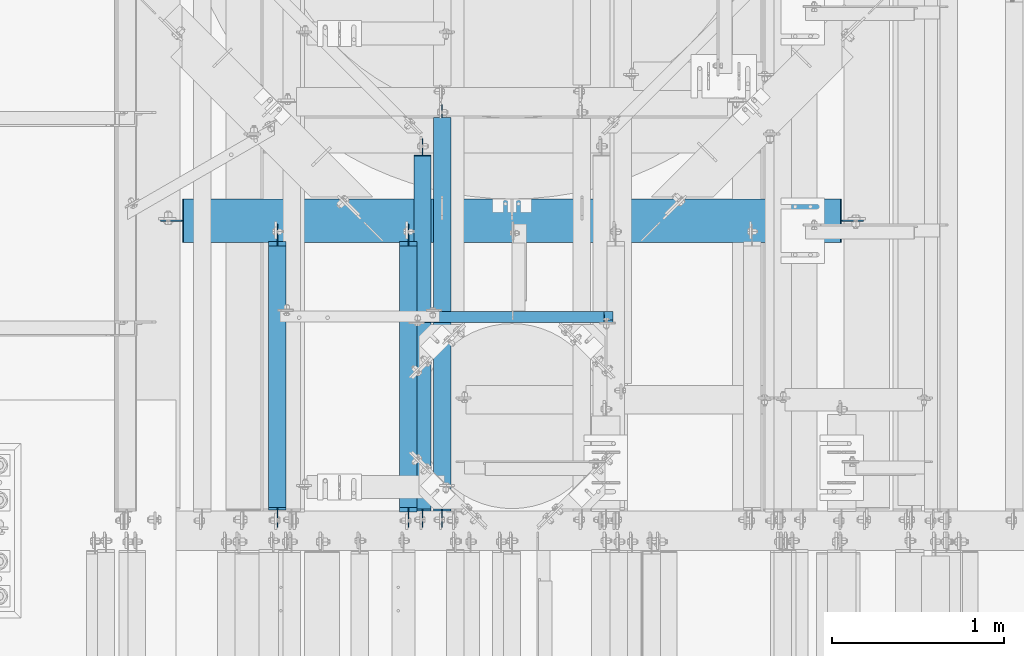
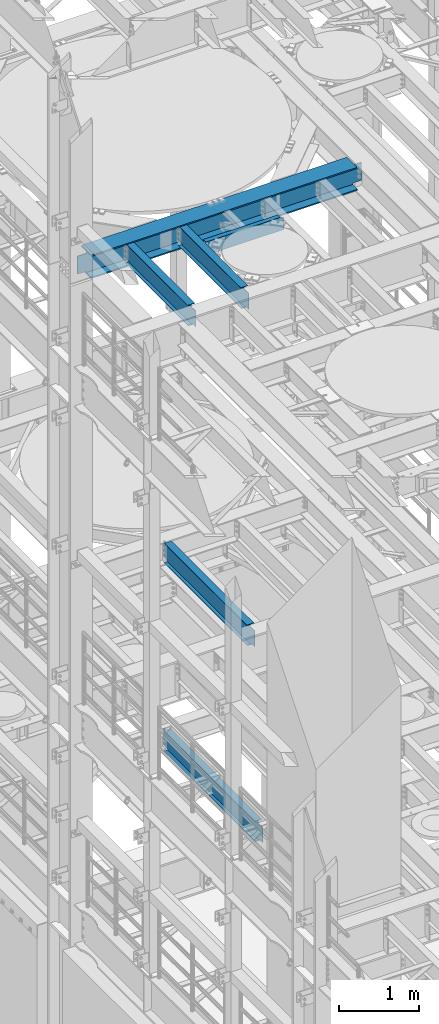
# One storey, part 1044 of 1876: 6 beams, 6 elements without a shape of their own.
"""IFC2X3 building model written with IfcOpenShell, lengths in millimetres."""

from ifc_helpers import new_model, si_unit, frame, origin_with_axes, place, context, subcontext, project, spatial, faceted_brep, material, type_object, element, aggregate, save


model = new_model("IFC2X3")

# Units and contexts
model_context = context("Model", 3, precision=1e-05, world=origin_with_axes())
body_context = subcontext(model_context, "Body", "Model", "MODEL_VIEW")
ifc_project = project(units=[si_unit("LENGTHUNIT", "METRE", prefix="MILLI"), si_unit("AREAUNIT", "SQUARE_METRE"), si_unit("VOLUMEUNIT", "CUBIC_METRE"), si_unit("MASSUNIT", "GRAM", prefix="KILO"), si_unit("TIMEUNIT", "SECOND"), si_unit("PLANEANGLEUNIT", "RADIAN"), si_unit("SOLIDANGLEUNIT", "STERADIAN"), si_unit("THERMODYNAMICTEMPERATUREUNIT", "DEGREE_CELSIUS"), si_unit("LUMINOUSINTENSITYUNIT", "LUMEN")], contexts=[model_context])

# Site, building, storey
site_placement = place(None, origin_with_axes())
site = spatial("IfcSite", under=ifc_project, at=site_placement, CompositionType="ELEMENT")
building_placement = place(site_placement, origin_with_axes())
building = spatial("IfcBuilding", under=site, at=building_placement, Name="Undefined", CompositionType="ELEMENT")
storey_placement = place(building_placement, origin_with_axes())
storey = spatial("IfcBuildingStorey", under=building, at=storey_placement, Name="Undefined", CompositionType="ELEMENT", Elevation=0.0)

# Assembly, beam
assembly_1_placement = place(storey_placement, origin_with_axes())
assembly_1 = element("IfcElementAssembly", 1, at=assembly_1_placement, inside=storey, Name="BEAM", AssemblyPlace="NOTDEFINED", PredefinedType="RIGID_FRAME")
ifc_material_1 = material(Name="STEEL/A992")
beam_type_1 = type_object("IfcBeamType", Name="W12X16", PredefinedType="NOTDEFINED")
beam_1_placement = place(assembly_1_placement, frame((2584.45, 7620.0, 13157.2), z_axis=(0.0, 0.0, 1.0), x_axis=(0.0, 1.0, 0.0)))
beam_1 = element("IfcBeam", 2, at=beam_1_placement, type_object=beam_type_1, material=ifc_material_1, Name="BEAM", ObjectType="W12X16", context=body_context, shape_type="Brep", body=[
    faceted_brep([(1683.54375, -3.17500000000018, -146.049999999999), (1683.54375, -50.8000000000002, -146.049999999999), (1683.54375, -50.8000000000002, -152.4), (1683.54375, 50.8000000000002, -152.4), (1683.54375, 50.8000000000002, -146.049999999999), (1683.54375, 3.17500000000018, -146.049999999999), (1683.54375, 3.17500000000018, -139.699999809267), (1683.54375, -3.17500000000018, -139.699999809267), (1684.51047992259, 3.17500000000018, -134.839920291221), (1684.51047992259, -3.17500000000018, -134.839920291221), (1687.26349382307, 3.17500000000018, -130.719743823067), (1687.26349382307, -3.17500000000018, -130.719743823067), (1691.38367029122, 3.17500000000018, -127.966729922589), (1691.38367029122, -3.17500000000018, -127.966729922589), (1696.24374980926, 3.17500000000018, -127.000000000002), (1696.24374980926, -3.17500000000018, -127.000000000002), (1785.14375, -3.17500000000018, -127.000000000002), (1785.14375, 3.17500000000018, -127.000000000002), (134.14375, 3.17500000000018, 146.049999999999), (134.14375, 50.8000000000002, 146.049999999999), (1658.14375, 50.8000000000002, 146.049999999999), (1658.14375, 3.17500000000018, 146.049999999999), (108.74375, -3.17499999999995, -139.699999809261), (108.74375, 3.17500002570978, -139.699999809261), (108.74375, 3.17500009516311, -146.049999999999), (108.74375, 50.8, -146.049999999999), (108.74375, 50.8, -152.400000000001), (108.74375, -50.8, -152.400000000001), (108.74375, -50.8, -146.049999999999), (108.74375, -3.17499999999995, -146.049999999999), (107.777020077412, -3.17499999999995, -134.839920291215), (107.777020077412, 3.17500002492102, -134.839920291215), (105.024006176934, -3.17499999999995, -130.719743823061), (105.024006176934, 3.17500002425209, -130.719743823061), (100.90382970878, -3.17499999999995, -127.966729922584), (100.90382970878, 3.17500002380461, -127.966729922584), (96.0437501907345, -3.17499999999995, -126.999999999996), (96.0437501907345, 3.17500002364682, -126.999999999996), (19.84375, -3.17499999999995, -126.999999999996), (19.84375, 3.17499999999995, -126.999999999996), (19.84375, -3.17500000000018, 114.299999999999), (19.84375, 3.17500000000018, 114.299999999999), (121.443750190735, -3.17500000000018, 114.299999999999), (121.443750190735, 3.17500000000018, 114.299999999999), (126.303829708781, -3.17500000000018, 115.266729922587), (126.303829708781, 3.17500000000018, 115.266729922587), (130.424006176934, -3.17500000000018, 118.019743823064), (130.424006176934, 3.17500000000018, 118.019743823064), (133.177020077413, -3.17500000000018, 122.139920291218), (133.177020077413, 3.17500000000018, 122.139920291218), (134.14375, -3.17500000000018, 126.999999809264), (134.14375, 3.17500000000018, 126.999999809264), (134.14375, -50.8000000000002, 152.4), (134.14375, 50.8000000000002, 152.4), (134.14375, -3.17500000000018, 146.049999999999), (134.14375, -50.8000000000002, 146.049999999999), (1658.14375, -3.17500000000018, 146.049999999999), (1658.14375, -50.8000000000002, 146.049999999999), (1658.14375, -50.8000000000002, 152.4), (1658.14375, 50.8000000000002, 152.4), (1658.14375, -3.17500000000018, 120.649999809264), (1658.14375, 3.17500000000018, 120.649999809264), (1659.11047992259, -3.17500000000018, 115.789920291218), (1659.11047992259, 3.17500000000018, 115.789920291218), (1661.86349382306, -3.17500000000018, 111.669743823064), (1661.86349382306, 3.17500000000018, 111.669743823064), (1665.98367029122, -3.17500000000018, 108.916729922586), (1665.98367029122, 3.17500000000018, 108.916729922586), (1670.84374980926, -3.17500000000018, 107.949999999999), (1670.84374980926, 3.17500000000018, 107.949999999999), (1785.14375, -3.17500000000018, 107.949999999999), (1785.14375, 3.17500000000018, 107.949999999999)], [[[0, 1, 2, 3, 4, 5, 6, 7]], [[7, 6, 8, 9]], [[9, 8, 10, 11]], [[11, 10, 12, 13]], [[13, 12, 14, 15]], [[16, 15, 14, 17]], [[18, 19, 20, 21]], [[22, 23, 24, 25, 26, 27, 28, 29]], [[30, 31, 23, 22]], [[32, 33, 31, 30]], [[34, 35, 33, 32]], [[36, 37, 35, 34]], [[38, 39, 37, 36]], [[40, 41, 39, 38]], [[42, 43, 41, 40]], [[44, 45, 43, 42]], [[46, 47, 45, 44]], [[48, 49, 47, 46]], [[50, 51, 49, 48]], [[52, 53, 19, 18, 51, 50, 54, 55]], [[55, 54, 56, 57]], [[52, 55, 57, 58]], [[53, 52, 58, 59]], [[19, 53, 59, 20]], [[58, 57, 56, 60, 61, 21, 20, 59]], [[62, 63, 61, 60]], [[64, 65, 63, 62]], [[66, 67, 65, 64]], [[68, 69, 67, 66]], [[70, 71, 69, 68]], [[71, 70, 16, 17]], [[12, 10, 8, 6, 5, 24, 23, 31, 33, 35, 37, 39, 41, 43, 45, 47, 49, 51, 18, 21, 61, 63, 65, 67, 69, 71, 17, 14]], [[25, 24, 5, 4]], [[26, 25, 4, 3]], [[27, 26, 3, 2]], [[28, 27, 2, 1]], [[29, 28, 1, 0]], [[70, 68, 66, 64, 62, 60, 56, 54, 50, 48, 46, 44, 42, 40, 38, 36, 34, 32, 30, 22, 29, 0, 7, 9, 11, 13, 15, 16]]]),
])
aggregate(assembly_1, [beam_1])

assembly_2_placement = place(storey_placement, origin_with_axes())
assembly_2 = element("IfcElementAssembly", 3, at=assembly_2_placement, inside=storey, Name="BEAM", AssemblyPlace="NOTDEFINED", PredefinedType="RIGID_FRAME")
beam_2_placement = place(assembly_2_placement, frame((1822.45000000002, 7620.0, 13157.2), z_axis=(0.0, 0.0, 1.0), x_axis=(0.0, 1.0, 0.0)))
beam_2 = element("IfcBeam", 4, at=beam_2_placement, type_object=beam_type_1, material=ifc_material_1, Name="BEAM", ObjectType="W12X16", context=body_context, shape_type="Brep", body=[
    faceted_brep([(1683.54375, -3.17500000000018, -146.049999999999), (1683.54375, -50.8000000000002, -146.049999999999), (1683.54375, -50.8000000000002, -152.4), (1683.54375, 50.8000000000002, -152.4), (1683.54375, 50.8000000000002, -146.049999999999), (1683.54375, 3.17500000000018, -146.049999999999), (1683.54375, 3.17500000000018, -139.699999809267), (1683.54375, -3.17500000000018, -139.699999809267), (1684.51047992259, 3.17500000000018, -134.839920291221), (1684.51047992259, -3.17500000000018, -134.839920291221), (1687.26349382307, 3.17500000000018, -130.719743823067), (1687.26349382307, -3.17500000000018, -130.719743823067), (1691.38367029122, 3.17500000000018, -127.966729922589), (1691.38367029122, -3.17500000000018, -127.966729922589), (1696.24374980926, 3.17500000000018, -127.000000000002), (1696.24374980926, -3.17500000000018, -127.000000000002), (1785.14375, -3.17500000000018, -127.000000000002), (1785.14375, 3.17500000000018, -127.000000000002), (134.14375, 3.17500000000018, 146.049999999999), (134.14375, 50.8000000000002, 146.049999999999), (1658.14375, 50.8000000000002, 146.049999999999), (1658.14375, 3.17500000000018, 146.049999999999), (121.44375, -3.17500000000018, -139.699999809265), (121.44375, 3.17500000000018, -139.699999809265), (121.44375, 3.17500000000018, -146.049999999999), (121.44375, 50.8000000000002, -146.049999999999), (121.44375, 50.8000000000002, -152.4), (121.44375, -50.8000000000002, -152.4), (121.44375, -50.8000000000002, -146.049999999999), (121.44375, -3.17500000000018, -146.049999999999), (120.477020077413, -3.17500000000018, -134.839920291219), (120.477020077413, 3.17500000000018, -134.839920291219), (117.724006176934, -3.17500000000018, -130.719743823065), (117.724006176934, 3.17500000000018, -130.719743823065), (113.603829708781, -3.17500000000018, -127.966729922588), (113.603829708781, 3.17500000000018, -127.966729922588), (108.743750190735, -3.17500000000018, -127.0), (108.743750190735, 3.17500000000018, -127.0), (19.84375, -3.17499999999995, -126.999999999996), (19.84375, 3.17499999999995, -126.999999999996), (19.84375, -3.17500000000018, 114.299999999999), (19.84375, 3.17500000000018, 114.299999999999), (121.443750190735, -3.17500000000018, 114.299999999999), (121.443750190735, 3.17500000000018, 114.299999999999), (126.303829708781, -3.17500000000018, 115.266729922587), (126.303829708781, 3.17500000000018, 115.266729922587), (130.424006176934, -3.17500000000018, 118.019743823064), (130.424006176934, 3.17500000000018, 118.019743823064), (133.177020077413, -3.17500000000018, 122.139920291218), (133.177020077413, 3.17500000000018, 122.139920291218), (134.14375, -3.17500000000018, 126.999999809264), (134.14375, 3.17500000000018, 126.999999809264), (134.14375, -50.8000000000002, 152.4), (134.14375, 50.8000000000002, 152.4), (134.14375, -3.17500000000018, 146.049999999999), (134.14375, -50.8000000000002, 146.049999999999), (1658.14375, -3.17500000000018, 146.049999999999), (1658.14375, -50.8000000000002, 146.049999999999), (1658.14375, -50.8000000000002, 152.4), (1658.14375, 50.8000000000002, 152.4), (1658.14375, -3.17500000000018, 120.649999809264), (1658.14375, 3.17500000000018, 120.649999809264), (1659.11047992259, -3.17500000000018, 115.789920291218), (1659.11047992259, 3.17500000000018, 115.789920291218), (1661.86349382306, -3.17500000000018, 111.669743823064), (1661.86349382306, 3.17500000000018, 111.669743823064), (1665.98367029122, -3.17500000000018, 108.916729922586), (1665.98367029122, 3.17500000000018, 108.916729922586), (1670.84374980926, -3.17500000000018, 107.949999999999), (1670.84374980926, 3.17500000000018, 107.949999999999), (1785.14375, -3.17500000000018, 107.949999999999), (1785.14375, 3.17500000000018, 107.949999999999)], [[[0, 1, 2, 3, 4, 5, 6, 7]], [[7, 6, 8, 9]], [[9, 8, 10, 11]], [[11, 10, 12, 13]], [[13, 12, 14, 15]], [[16, 15, 14, 17]], [[18, 19, 20, 21]], [[22, 23, 24, 25, 26, 27, 28, 29]], [[30, 31, 23, 22]], [[32, 33, 31, 30]], [[34, 35, 33, 32]], [[36, 37, 35, 34]], [[38, 39, 37, 36]], [[40, 41, 39, 38]], [[42, 43, 41, 40]], [[44, 45, 43, 42]], [[46, 47, 45, 44]], [[48, 49, 47, 46]], [[50, 51, 49, 48]], [[52, 53, 19, 18, 51, 50, 54, 55]], [[55, 54, 56, 57]], [[52, 55, 57, 58]], [[53, 52, 58, 59]], [[19, 53, 59, 20]], [[58, 57, 56, 60, 61, 21, 20, 59]], [[62, 63, 61, 60]], [[64, 65, 63, 62]], [[66, 67, 65, 64]], [[68, 69, 67, 66]], [[70, 71, 69, 68]], [[71, 70, 16, 17]], [[12, 10, 8, 6, 5, 24, 23, 31, 33, 35, 37, 39, 41, 43, 45, 47, 49, 51, 18, 21, 61, 63, 65, 67, 69, 71, 17, 14]], [[25, 24, 5, 4]], [[26, 25, 4, 3]], [[27, 26, 3, 2]], [[28, 27, 2, 1]], [[29, 28, 1, 0]], [[70, 68, 66, 64, 62, 60, 56, 54, 50, 48, 46, 44, 42, 40, 38, 36, 34, 32, 30, 22, 29, 0, 7, 9, 11, 13, 15, 16]]]),
])
aggregate(assembly_2, [beam_2])

assembly_3_placement = place(storey_placement, origin_with_axes())
assembly_3 = element("IfcElementAssembly", 5, at=assembly_3_placement, inside=storey, Name="BEAM", AssemblyPlace="NOTDEFINED", PredefinedType="RIGID_FRAME")
beam_3_placement = place(assembly_3_placement, frame((2667.0, 7620.0, 8001.0), z_axis=(0.0, 0.0, 1.0), x_axis=(0.0, 1.0, 0.0)))
beam_3 = element("IfcBeam", 6, at=beam_3_placement, type_object=beam_type_1, material=ifc_material_1, Name="BEAM", ObjectType="W12X16", context=body_context, shape_type="Brep", body=[
    faceted_brep([(19.84375, -3.17499999999995, -126.999999999996), (19.84375, 3.17499999999995, -126.999999999996), (102.393750190735, 3.17500000000018, -127.000000000001), (102.393750190735, -3.17500000000018, -127.000000000001), (107.25382970878, 3.17500000000018, -127.966729922588), (107.25382970878, -3.17500000000018, -127.966729922588), (111.374006176934, 3.17500000000018, -130.719743823067), (111.374006176934, -3.17500000000018, -130.719743823067), (114.127020077412, 3.17500000000018, -134.839920291221), (114.127020077412, -3.17500000000018, -134.839920291221), (115.09375, -3.17500000000018, -139.699999809266), (115.09375, 3.17500000000018, -139.699999809266), (115.09375, 3.17500000000018, -146.05), (115.09375, 50.8000000000002, -146.05), (115.09375, 50.8000000000002, -152.4), (115.09375, -50.8000000000002, -152.4), (115.09375, -50.8000000000002, -146.05), (115.09375, -3.17500000000018, -146.05), (2180.43124999999, 50.8000000000002, 146.05), (2180.43124999999, 3.17500000000018, 146.05), (127.79375, 3.17500000000018, 146.05), (127.79375, 50.8000000000002, 146.05), (115.093750190735, -3.17500000000018, 114.299999999999), (115.093750190735, 3.17500000000018, 114.299999999999), (19.84375, 3.17500000000018, 114.299999999999), (19.84375, -3.17500000000018, 114.299999999999), (119.95382970878, -3.17500000000018, 115.266729922587), (119.95382970878, 3.17500000000018, 115.266729922587), (124.074006176934, -3.17500000000018, 118.019743823065), (124.074006176934, 3.17500000000018, 118.019743823065), (126.827020077412, -3.17500000000018, 122.139920291219), (126.827020077412, 3.17500000000018, 122.139920291219), (127.79375, -3.17500000000018, 126.999999809264), (127.79375, 3.17500000000018, 126.999999809264), (2180.43124999999, -50.8000000000002, 152.4), (2180.43124999999, 50.8000000000002, 152.4), (127.79375, 50.8000000000002, 152.4), (127.79375, -50.8000000000002, 152.4), (2180.43124999999, -50.8000000000002, 146.05), (127.79375, -50.8000000000002, 146.05), (2180.43124999999, -3.17500000000018, 146.05), (127.79375, -3.17500000000018, 146.05), (2180.43124999999, -3.17500000000018, 139.699999809265), (2180.43124999999, 3.17500000000018, 139.699999809265), (2181.39797992258, -3.17500000000018, 134.83992029122), (2181.39797992258, 3.17500000000018, 134.83992029122), (2184.15099382306, -3.17500000000018, 130.719743823066), (2184.15099382306, 3.17500000000018, 130.719743823066), (2188.27117029121, -3.17500000000018, 127.966729922588), (2188.27117029121, 3.17500000000018, 127.966729922588), (2193.13124980926, -3.17500000000018, 127.0), (2193.13124980926, 3.17500000000018, 127.0), (2282.03125, -3.17500000000018, 127.0), (2282.03125, 3.17500000000018, 127.0), (2282.03125, -3.17500000000018, -127.0), (2282.03125, 3.17500000000018, -127.0), (2199.48124980926, -3.17500000000018, -127.0), (2199.48124980926, 3.17500000000018, -127.0), (2194.62117029122, -3.17500000000018, -127.966729922588), (2194.62117029122, 3.17500000000018, -127.966729922588), (2190.50099382306, -3.17500000000018, -130.719743823066), (2190.50099382306, 3.17500000000018, -130.719743823066), (2187.74797992258, -3.17500000000018, -134.83992029122), (2187.74797992258, 3.17500000000018, -134.83992029122), (2186.78124999999, -3.17500000000018, -139.699999809265), (2186.78124999999, 3.17500000000018, -139.699999809265), (2186.78124999999, -3.17500000000018, -146.05), (2186.78124999999, -50.8000000000002, -146.05), (2186.78124999999, -50.8000000000002, -152.4), (2186.78124999999, 50.8000000000002, -152.4), (2186.78124999999, 50.8000000000002, -146.05), (2186.78124999999, 3.17500000000018, -146.05)], [[[0, 1, 2, 3]], [[3, 2, 4, 5]], [[5, 4, 6, 7]], [[7, 6, 8, 9]], [[10, 11, 12, 13, 14, 15, 16, 17]], [[9, 8, 11, 10]], [[18, 19, 20, 21]], [[22, 23, 24, 25]], [[26, 27, 23, 22]], [[28, 29, 27, 26]], [[30, 31, 29, 28]], [[32, 33, 31, 30]], [[34, 35, 36, 37]], [[38, 34, 37, 39]], [[40, 38, 39, 41]], [[37, 36, 21, 20, 33, 32, 41, 39]], [[35, 18, 21, 36]], [[34, 38, 40, 42, 43, 19, 18, 35]], [[44, 45, 43, 42]], [[46, 47, 45, 44]], [[48, 49, 47, 46]], [[50, 51, 49, 48]], [[52, 53, 51, 50]], [[53, 52, 54, 55]], [[54, 56, 57, 55]], [[58, 59, 57, 56]], [[60, 61, 59, 58]], [[62, 63, 61, 60]], [[64, 65, 63, 62]], [[66, 67, 68, 69, 70, 71, 65, 64]], [[67, 66, 17, 16]], [[68, 67, 16, 15]], [[69, 68, 15, 14]], [[70, 69, 14, 13]], [[71, 70, 13, 12]], [[6, 4, 2, 1, 24, 23, 27, 29, 31, 33, 20, 19, 43, 45, 47, 49, 51, 53, 55, 57, 59, 61, 63, 65, 71, 12, 11, 8]], [[25, 24, 1, 0]], [[66, 64, 62, 60, 58, 56, 54, 52, 50, 48, 46, 44, 42, 40, 41, 32, 30, 28, 26, 22, 25, 0, 3, 5, 7, 9, 10, 17]]]),
])
aggregate(assembly_3, [beam_3])

assembly_4_placement = place(storey_placement, origin_with_axes())
assembly_4 = element("IfcElementAssembly", 7, at=assembly_4_placement, inside=storey, Name="BEAM", AssemblyPlace="NOTDEFINED", PredefinedType="RIGID_FRAME")
beam_4_placement = place(assembly_4_placement, frame((2781.3, 7620.0, 4978.4), z_axis=(0.0, 0.0, 1.0), x_axis=(0.0, 1.0, 0.0)))
beam_4 = element("IfcBeam", 8, at=beam_4_placement, type_object=beam_type_1, material=ifc_material_1, Name="BEAM", ObjectType="W12X16", context=body_context, shape_type="Brep", body=[
    faceted_brep([(2384.425, -3.17500000000018, -146.05), (2384.425, -50.8000000000002, -146.05), (2384.425, -50.8000000000002, -152.4), (2384.425, 50.8000000000002, -152.4), (2384.425, 50.8000000000002, -146.05), (2384.425, 3.17500000000018, -146.05), (2384.425, 3.17500000000018, -139.699999809264), (2384.425, -3.17500000000018, -139.699999809264), (2385.39172992259, 3.17500000000018, -134.839920291219), (2385.39172992259, -3.17500000000018, -134.839920291219), (2388.14474382306, 3.17500000000018, -130.719743823065), (2388.14474382306, -3.17500000000018, -130.719743823065), (2392.26492029122, 3.17500000000018, -127.966729922587), (2392.26492029122, -3.17500000000018, -127.966729922587), (2397.12499980926, 3.17500000000018, -126.999999999999), (2397.12499980926, -3.17500000000018, -126.999999999999), (2479.675, -3.17500000000018, -126.999999999999), (2479.675, 3.17500000000018, -126.999999999999), (127.79375, 3.17500000000018, 146.05), (127.79375, 50.8000000000002, 146.05), (2403.475, 50.8000000000002, 146.05), (2403.475, 3.17500000000018, 146.05), (115.09375, -3.17500000000018, -139.699999809266), (115.09375, 3.17500000000018, -139.699999809266), (115.09375, 3.17500000000018, -146.05), (115.09375, 50.8000000000002, -146.05), (115.09375, 50.8000000000002, -152.4), (115.09375, -50.8000000000002, -152.4), (115.09375, -50.8000000000002, -146.05), (115.09375, -3.17500000000018, -146.05), (114.127020077412, -3.17500000000018, -134.839920291221), (114.127020077412, 3.17500000000018, -134.839920291221), (111.374006176934, -3.17500000000018, -130.719743823067), (111.374006176934, 3.17500000000018, -130.719743823067), (107.25382970878, -3.17500000000018, -127.966729922588), (107.25382970878, 3.17500000000018, -127.966729922588), (102.393750190735, -3.17500000000018, -127.000000000001), (102.393750190735, 3.17500000000018, -127.000000000001), (19.84375, -3.17499999999995, -126.999999999996), (19.84375, 3.17499999999995, -126.999999999996), (19.84375, -3.17500000000018, 114.299999999999), (19.84375, 3.17500000000018, 114.299999999999), (115.093750190735, -3.17500000000018, 114.299999999999), (115.093750190735, 3.17500000000018, 114.299999999999), (119.95382970878, -3.17500000000018, 115.266729922587), (119.95382970878, 3.17500000000018, 115.266729922587), (124.074006176934, -3.17500000000018, 118.019743823065), (124.074006176934, 3.17500000000018, 118.019743823065), (126.827020077412, -3.17500000000018, 122.139920291219), (126.827020077412, 3.17500000000018, 122.139920291219), (127.79375, -3.17500000000018, 126.999999809264), (127.79375, 3.17500000000018, 126.999999809264), (127.79375, -50.8000000000002, 152.4), (127.79375, 50.8000000000002, 152.4), (127.79375, -3.17500000000018, 146.05), (127.79375, -50.8000000000002, 146.05), (2403.475, -3.17500000000018, 146.05), (2403.475, -50.8000000000002, 146.05), (2403.475, -50.8000000000002, 152.4), (2403.475, 50.8000000000002, 152.4), (2403.475, -3.17500000000018, 139.699999809266), (2403.475, 3.17500000000018, 139.699999809266), (2404.44172992259, -3.17500000000018, 134.839920291221), (2404.44172992259, 3.17500000000018, 134.839920291221), (2407.19474382306, -3.17500000000018, 130.719743823067), (2407.19474382306, 3.17500000000018, 130.719743823067), (2411.31492029122, -3.17500000000018, 127.966729922588), (2411.31492029122, 3.17500000000018, 127.966729922588), (2416.17499980926, -3.17500000000018, 127.000000000001), (2416.17499980926, 3.17500000000018, 127.000000000001), (2479.675, -3.17500000000018, 127.000000000001), (2479.675, 3.17500000000018, 127.000000000001)], [[[0, 1, 2, 3, 4, 5, 6, 7]], [[7, 6, 8, 9]], [[9, 8, 10, 11]], [[11, 10, 12, 13]], [[13, 12, 14, 15]], [[16, 15, 14, 17]], [[18, 19, 20, 21]], [[22, 23, 24, 25, 26, 27, 28, 29]], [[30, 31, 23, 22]], [[32, 33, 31, 30]], [[34, 35, 33, 32]], [[36, 37, 35, 34]], [[38, 39, 37, 36]], [[40, 41, 39, 38]], [[42, 43, 41, 40]], [[44, 45, 43, 42]], [[46, 47, 45, 44]], [[48, 49, 47, 46]], [[50, 51, 49, 48]], [[52, 53, 19, 18, 51, 50, 54, 55]], [[55, 54, 56, 57]], [[52, 55, 57, 58]], [[53, 52, 58, 59]], [[19, 53, 59, 20]], [[58, 57, 56, 60, 61, 21, 20, 59]], [[62, 63, 61, 60]], [[64, 65, 63, 62]], [[66, 67, 65, 64]], [[68, 69, 67, 66]], [[70, 71, 69, 68]], [[71, 70, 16, 17]], [[12, 10, 8, 6, 5, 24, 23, 31, 33, 35, 37, 39, 41, 43, 45, 47, 49, 51, 18, 21, 61, 63, 65, 67, 69, 71, 17, 14]], [[25, 24, 5, 4]], [[26, 25, 4, 3]], [[27, 26, 3, 2]], [[28, 27, 2, 1]], [[29, 28, 1, 0]], [[70, 68, 66, 64, 62, 60, 56, 54, 50, 48, 46, 44, 42, 40, 38, 36, 34, 32, 30, 22, 29, 0, 7, 9, 11, 13, 15, 16]]]),
])
aggregate(assembly_4, [beam_4])

assembly_5_placement = place(storey_placement, origin_with_axes())
assembly_5 = element("IfcElementAssembly", 9, at=assembly_5_placement, inside=storey, Name="BEAM", AssemblyPlace="NOTDEFINED", PredefinedType="RIGID_FRAME")
ifc_material_2 = material(Name="STEEL/A36")
beam_type_2 = type_object("IfcBeamType", Name="C8X18.75", PredefinedType="NOTDEFINED")
beam_5_placement = place(assembly_5_placement, frame((2584.45, 8864.6, 13208.0), z_axis=(0.0, 0.0, -1.0), x_axis=(1.0, 0.0, 0.0)))
beam_5 = element("IfcBeam", 10, at=beam_5_placement, type_object=beam_type_2, material=ifc_material_2, Name="BEAM", ObjectType="C8X18.75", context=body_context, shape_type="Brep", body=[
    faceted_brep([(15.8749999999991, 19.0500000000002, -82.5499999999993), (15.8749999999991, 31.75, -82.5499999999993), (53.9750001907169, 31.75, -82.5500000000011), (53.9750001907169, 19.0500000000002, -82.5500000000011), (58.8350797087624, 31.75, -83.5167299225886), (58.8350797087624, 19.0500000000002, -83.5167299225886), (62.955256176916, 31.75, -86.2697438230662), (62.955256176916, 19.0500000000002, -86.2697438230662), (64.7135857534681, 19.0500000000002, -88.9012700000003), (65.708270077394, 31.75, -90.3899202912198), (65.708270077394, 10.1145240623009, -90.3899202912198), (66.674999999982, -19.0576219043596, -95.2499998092662), (66.674999999982, 31.75, -95.2499998092662), (66.674999999982, 31.75, -101.6), (66.674999999982, -31.75, -101.6), (66.674999999982, -31.75, -97.3645500000002), (15.8749999999991, 31.75, 101.599999999999), (15.8749999999991, -31.75, 101.599999999999), (1190.625, -31.75, 101.6), (1190.625, 31.75, 101.6), (15.8749999999991, -31.75, 97.3645499999984), (1190.625, -31.75, 97.3645500000002), (15.8749999999991, 19.0500000000002, 88.9012699999985), (1190.625, 19.0499999999993, 88.9012700000003), (1190.625, 19.0499999999993, -82.5500000000011), (1190.625, 31.75, -82.5500000000011), (1152.52499980927, 19.0499999999993, -82.5500000000011), (1152.52499980927, 31.75, -82.5500000000011), (1147.66492029122, 19.0499999999993, -83.5167299225886), (1147.66492029122, 31.75, -83.5167299225886), (1143.54474382307, 19.0499999999993, -86.2697438230662), (1143.54474382307, 31.75, -86.2697438230662), (1141.78641424651, 19.0499999999993, -88.9012700000003), (1140.79172992259, 10.1145240622991, -90.3899202912216), (1140.79172992259, 31.75, -90.3899202912216), (1139.825, -19.0576219043596, -95.2499998092662), (1139.825, 31.75, -95.2499998092662), (1139.825, -31.75, -97.3645500000002), (1139.825, -31.75, -101.6), (1139.825, 31.75, -101.6)], [[[0, 1, 2, 3]], [[3, 2, 4, 5]], [[5, 4, 6, 7]], [[8, 7, 6, 9, 10]], [[11, 12, 13, 14, 15]], [[10, 9, 12, 11]], [[16, 17, 18, 19]], [[17, 20, 21, 18]], [[20, 22, 23, 21]], [[19, 18, 21, 23, 24, 25]], [[24, 26, 27, 25]], [[28, 29, 27, 26]], [[30, 31, 29, 28]], [[32, 33, 34, 31, 30]], [[35, 36, 34, 33]], [[37, 38, 39, 36, 35]], [[38, 37, 15, 14]], [[39, 38, 14, 13]], [[6, 4, 2, 1, 16, 19, 25, 27, 29, 31, 34, 36, 39, 13, 12, 9]], [[22, 20, 17, 16, 1, 0]], [[32, 30, 28, 26, 24, 23, 22, 0, 3, 5, 7, 8]], [[37, 35, 33, 32, 8, 10, 11, 15]]]),
])
aggregate(assembly_5, [beam_5])

assembly_6_placement = place(storey_placement, origin_with_axes())
assembly_6 = element("IfcElementAssembly", 11, at=assembly_6_placement, inside=storey, Name="BEAM", AssemblyPlace="NOTDEFINED", PredefinedType="RIGID_FRAME")
beam_type_3 = type_object("IfcBeamType", Name="W14X68", PredefinedType="NOTDEFINED")
beam_6_placement = place(assembly_6_placement, frame((1125.53750000002, 9423.4, 13131.8), z_axis=(0.0, 0.0, 1.0), x_axis=(1.0, 0.0, 0.0)))
beam_6 = element("IfcBeam", 12, at=beam_6_placement, type_object=beam_type_3, material=ifc_material_1, Name="BEAM", ObjectType="W14X68", context=body_context, shape_type="Brep", body=[
    faceted_brep([(3979.86249844431, -5.55624999999964, -158.75), (3979.86249844431, -127.0, -158.75), (3979.86249844431, -127.0, -177.799999999999), (3979.86249844431, 127.0, -177.799999999999), (3979.86249844431, 127.0, -158.75), (3979.86249844431, 5.55624999999964, -158.75), (3979.86249844431, 5.55624999999964, -152.399999809264), (3979.86249844431, -5.55624999999964, -152.399999809264), (3980.8292283669, 5.55624999999964, -147.539920291218), (3980.8292283669, -5.55624999999964, -147.539920291218), (3983.58224226738, 5.55624999999964, -143.419743823064), (3983.58224226738, -5.55624999999964, -143.419743823064), (3987.70241873553, 5.55624999999964, -140.666729922586), (3987.70241873553, -5.55624999999964, -140.666729922586), (3992.56249825358, 5.55624999999964, -139.699999999999), (3992.56249825358, -5.55624999999964, -139.699999999999), (4106.86249844431, -5.55624999999964, -139.699999999999), (4106.86249844431, 5.55624999999964, -139.699999999999), (150.812504800616, 5.55624999999964, 158.75), (150.812504800616, 127.0, 158.75), (3973.51249844431, 127.0, 158.75), (3973.51249844431, 5.55624999999964, 158.75), (144.462504800616, -5.55624999999964, -152.399999809264), (144.462504800616, 5.55624999999964, -152.399999809264), (144.462504800616, 5.55624999999964, -158.75), (144.462504800616, 127.0, -158.75), (144.462504800616, 127.0, -177.799999999999), (144.462504800616, -127.0, -177.799999999999), (144.462504800616, -127.0, -158.75), (144.462504800616, -5.55624999999964, -158.75), (143.495774878028, -5.55624999999964, -147.539920291218), (143.495774878028, 5.55624999999964, -147.539920291218), (140.74276097755, -5.55624999999964, -143.419743823064), (140.74276097755, 5.55624999999964, -143.419743823064), (136.622584509397, -5.55624999999964, -140.666729922586), (136.622584509397, 5.55624999999964, -140.666729922586), (131.762504991351, -5.55624999999964, -139.699999999999), (131.762504991351, 5.55624999999964, -139.699999999999), (17.4625048006169, -5.55624999999964, -139.699999999999), (17.4625048006169, 5.55624999999964, -139.699999999999), (17.4625048006169, -5.55624999999964, 133.35), (17.4625048006169, 5.55624999999964, 133.35), (138.112504991351, -5.55624999999964, 133.35), (138.112504991351, 5.55624999999964, 133.35), (142.972584509396, -5.55624999999964, 134.316729922588), (142.972584509396, 5.55624999999964, 134.316729922588), (147.09276097755, -5.55624999999964, 137.069743823065), (147.09276097755, 5.55624999999964, 137.069743823065), (149.845774878028, -5.55624999999964, 141.189920291219), (149.845774878028, 5.55624999999964, 141.189920291219), (150.812504800616, -5.55624999999964, 146.049999809266), (150.812504800616, 5.55624999999964, 146.049999809266), (150.812504800616, -127.0, 177.799999999999), (150.812504800616, 127.0, 177.799999999999), (150.812504800616, -5.55624999999964, 158.75), (150.812504800616, -127.0, 158.75), (3973.51249844431, -5.55624999999964, 158.75), (3973.51249844431, -127.0, 158.75), (3973.51249844431, -127.0, 177.799999999999), (3973.51249844431, 127.0, 177.799999999999), (3973.51249844431, -5.55624999999964, 146.049999809266), (3973.51249844431, 5.55624999999964, 146.049999809266), (3974.4792283669, -5.55624999999964, 141.189920291219), (3974.4792283669, 5.55624999999964, 141.189920291219), (3977.23224226738, -5.55624999999964, 137.069743823065), (3977.23224226738, 5.55624999999964, 137.069743823065), (3981.35241873553, -5.55624999999964, 134.316729922588), (3981.35241873553, 5.55624999999964, 134.316729922588), (3986.21249825358, -5.55624999999964, 133.35), (3986.21249825358, 5.55624999999964, 133.35), (4106.86249844431, -5.55624999999964, 133.35), (4106.86249844431, 5.55624999999964, 133.35)], [[[0, 1, 2, 3, 4, 5, 6, 7]], [[7, 6, 8, 9]], [[9, 8, 10, 11]], [[11, 10, 12, 13]], [[13, 12, 14, 15]], [[16, 15, 14, 17]], [[18, 19, 20, 21]], [[22, 23, 24, 25, 26, 27, 28, 29]], [[30, 31, 23, 22]], [[32, 33, 31, 30]], [[34, 35, 33, 32]], [[36, 37, 35, 34]], [[38, 39, 37, 36]], [[40, 41, 39, 38]], [[42, 43, 41, 40]], [[44, 45, 43, 42]], [[46, 47, 45, 44]], [[48, 49, 47, 46]], [[50, 51, 49, 48]], [[52, 53, 19, 18, 51, 50, 54, 55]], [[55, 54, 56, 57]], [[52, 55, 57, 58]], [[53, 52, 58, 59]], [[19, 53, 59, 20]], [[58, 57, 56, 60, 61, 21, 20, 59]], [[62, 63, 61, 60]], [[64, 65, 63, 62]], [[66, 67, 65, 64]], [[68, 69, 67, 66]], [[70, 71, 69, 68]], [[71, 70, 16, 17]], [[12, 10, 8, 6, 5, 24, 23, 31, 33, 35, 37, 39, 41, 43, 45, 47, 49, 51, 18, 21, 61, 63, 65, 67, 69, 71, 17, 14]], [[25, 24, 5, 4]], [[26, 25, 4, 3]], [[27, 26, 3, 2]], [[28, 27, 2, 1]], [[29, 28, 1, 0]], [[70, 68, 66, 64, 62, 60, 56, 54, 50, 48, 46, 44, 42, 40, 38, 36, 34, 32, 30, 22, 29, 0, 7, 9, 11, 13, 15, 16]]]),
])
aggregate(assembly_6, [beam_6])

save(model, "model.ifc")
